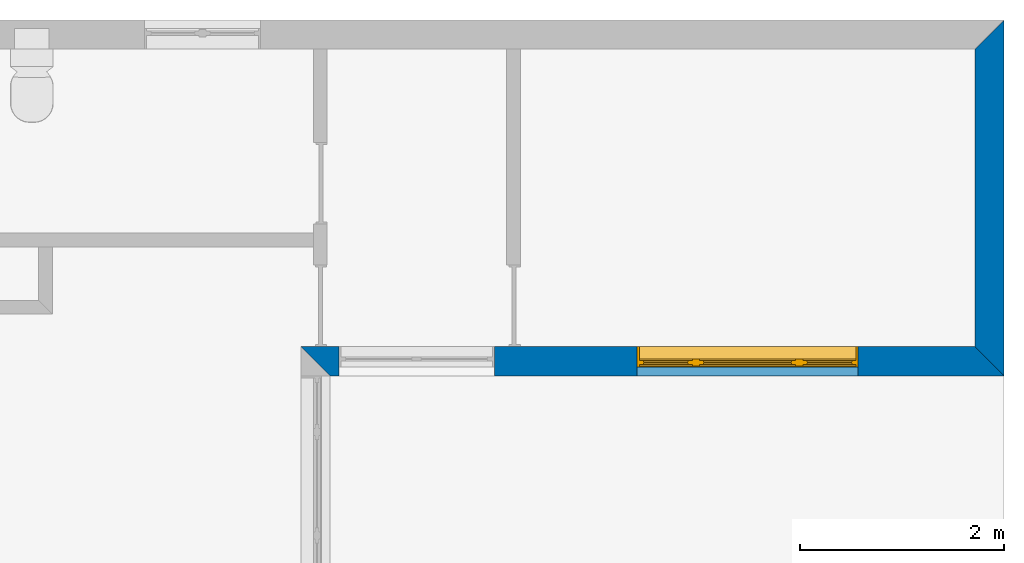
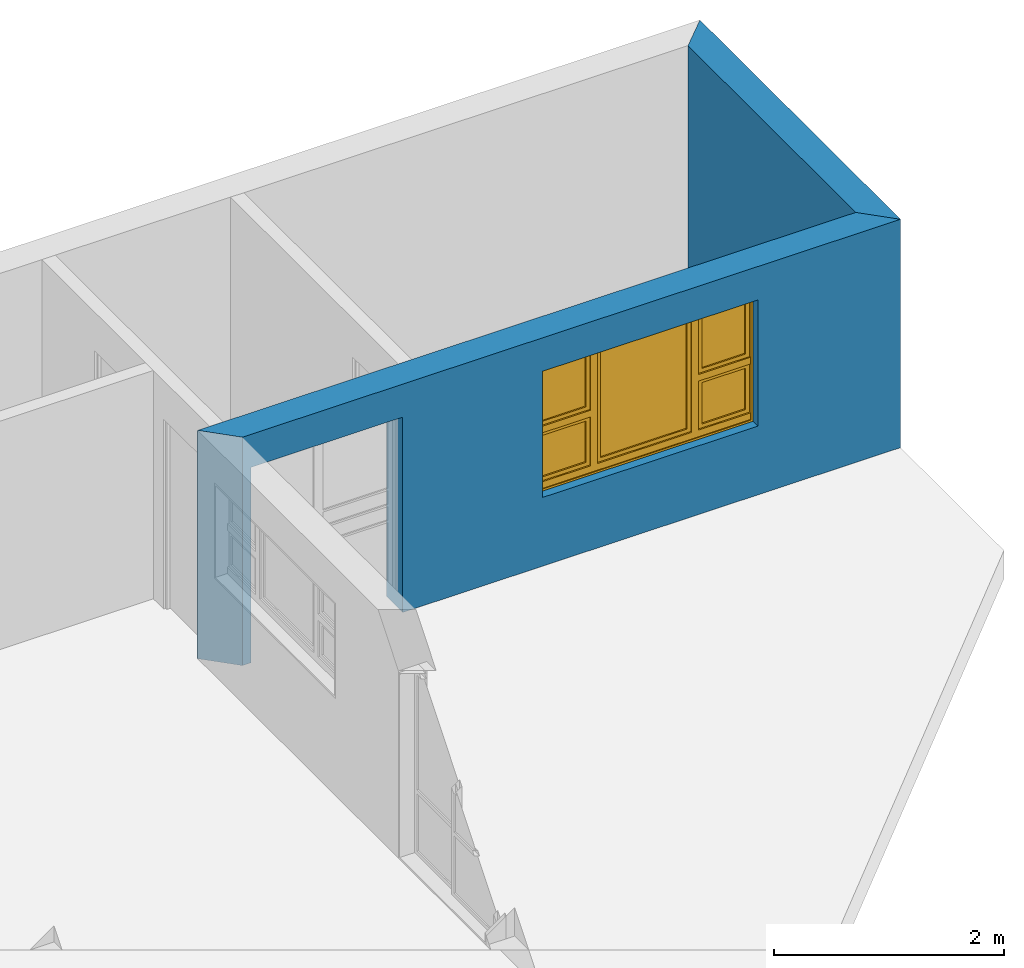
# One storey, part 7 of 15: 2 walls, 1 window, 2 openings.
"""IFC4 building model written with IfcOpenShell, lengths in millimetres."""

from ifc_helpers import new_model, entity, si_unit, converted_unit, frame, origin_with_axes, origin_2d_with_axis, place, context, subcontext, project, spatial, line, indexed_curve, outline, extrude, clip, halfspace, polygons, source, transform, mapped, material, layer, layer_set, layer_usage, type_object, type_shapes, element, fill, save


model = new_model("IFC4")

# Units and contexts
model_context = context("Model", 3, precision=1e-05, world=origin_with_axes())
plan_context = context("Plan", 2, precision=1e-05, world=origin_2d_with_axis())
body_context = subcontext(model_context, "Body", "Model", "MODEL_VIEW")
ifc_project = project(units=[si_unit("VOLUMEUNIT", "CUBIC_METRE"), si_unit("LENGTHUNIT", "METRE", prefix="MILLI"), converted_unit("PLANEANGLEUNIT", "degree", entity("IfcReal", 0.0174532925199433), si_unit("PLANEANGLEUNIT", "RADIAN"), dimensions=[0, 0, 0, 0, 0, 0, 0]), si_unit("AREAUNIT", "SQUARE_METRE")], contexts=[model_context, plan_context])

# Site, building, storey
site_placement = place(None, origin_with_axes())
site = spatial("IfcSite", under=ifc_project, at=site_placement)
building_placement = place(site_placement, origin_with_axes())
building = spatial("IfcBuilding", under=site, at=building_placement, Name="Building")
storey_placement = place(building_placement, origin_with_axes())
storey = spatial("IfcBuildingStorey", under=building, at=storey_placement, Name="EXISTING")

# Wall, openings, window
ifc_material = material()
ifc_layer = layer(ifc_material, 285.0, Name="brick")
ifc_layer_set = layer_set([ifc_layer])
ifc_layer_usage_1 = layer_usage(ifc_layer_set, "AXIS2", "POSITIVE", 0.0)
wall_type = type_object("IfcWallType", Name="285mm Wall", PredefinedType="STANDARD", material=ifc_layer_set)
wall_1_placement = place(storey_placement, frame((13209.1217041016, 2256.66809082031, 0.0), z_axis=(0.0, 0.0, 1.0), x_axis=(0.999999999999993, 1.19209282445353e-07, 0.0)))
wall_1 = element("IfcWall", 1, at=wall_1_placement, inside=storey, type_object=wall_type, material=ifc_layer_usage_1, Name="Wall", context=body_context, shape_type="Clipping", body=[
    clip(clip(extrude(outline(indexed_curve([(0.0, 0.0), (0.0, 285.0), (6894.99959678732, 285.0), (6894.99959678732, 0.0), (0.0, 0.0)], self_intersect=False)), origin_with_axes(), (0.0, 0.0, 1.0), 2425.00019073486), halfspace(frame((284.999847412109, 0.0, 0.0), z_axis=(-0.70710676908493, -0.70710676908493, 0.0), x_axis=(-0.707106781186547, 0.707106781186547, 0.0)), False)), halfspace(frame((6894.99950408936, 0.0, 0.0), z_axis=(0.70710676908493, 0.70710676908493, 0.0), x_axis=(0.707106781186547, -0.707106781186547, 0.0)), False)),
])
shared_shape_1 = source(origin_with_axes(), body_context, "Body", "SweptSolid", [
    extrude(outline(indexed_curve([(0.0, 0.0), (2165.00048828125, 0.0), (2165.00048828125, 1340.00048828125), (0.0, 1340.00048828125)], segments=[line(1, 2, 3, 4, 1)])), frame((-5.96046390910487e-07, -600.0, 0.0), z_axis=(0.0, -1.0, 0.0), x_axis=(1.0, 0.0, 0.0)), (0.0, 0.0, -1.0), 1200.0),
])
opening_1_placement = place(wall_1_placement, frame((5461.99893951417, 136.110782623295, 730.000019073486), z_axis=(0.0, 0.0, 1.0), x_axis=(-0.999999999999989, 1.50995802528085e-07, 0.0)))
opening_1 = element("IfcOpeningElement", 2, at=opening_1_placement, cuts=wall_1, Name="Opening", PredefinedType="OPENING", context=body_context, shape_type="MappedRepresentation", body=[
    mapped(shared_shape_1, transform((0.0, 0.0, 0.0), x_axis=(1.0, 0.0, 0.0), y_axis=(0.0, 1.0, 0.0), z_axis=(0.0, 0.0, 1.0), scale=1.0)),
])
shared_shape_2 = source(origin_with_axes(), body_context, "Body", "SweptSolid", [
    extrude(outline(indexed_curve([(0.0, 0.0), (1525.00244140625, 0.0), (1525.00244140625, 2075.0029296875), (0.0, 2075.0029296875)], segments=[line(1, 2, 3, 4, 1)])), frame((1.19209282445354e-07, -600.0, 0.0), z_axis=(0.0, -1.0, 0.0), x_axis=(1.0, 0.0, 0.0)), (0.0, 0.0, -1.0), 1200.0),
])
opening_2_placement = place(wall_1_placement, frame((1895.00141143799, -33.8461399078334, 0.0), z_axis=(0.0, 0.0, 1.0), x_axis=(-0.999999999999989, 1.50995802528085e-07, 0.0)))
element("IfcOpeningElement", 3, at=opening_2_placement, cuts=wall_1, PredefinedType="OPENING", context=body_context, shape_type="MappedRepresentation", body=[
    mapped(shared_shape_2, transform((0.0, 0.0, 0.0), x_axis=(1.0, 0.0, 0.0), y_axis=(0.0, 1.0, 0.0), z_axis=(0.0, 0.0, 1.0), scale=1.0)),
])
window_type = type_object("IfcWindowType", Name="Ex.2165x1340", PartitioningType="NOTDEFINED", PredefinedType="WINDOW")
shared_shape_3 = source(origin_with_axes(), body_context, "Body", "Tessellation", [
    polygons([(2165.00024414062, -148.888916015625, 0.0), (2165.00024414062, -148.888916015625, 19.999979019165), (0.000119209282274824, -148.888977050781, 0.0), (0.000119209282274824, -148.888977050781, 19.999979019165), (2165.00024414062, 51.1110572814941, 0.0), (2165.00024414062, 51.1110572814941, 19.999979019165), (0.000119209282274824, 51.1110000610352, 0.0), (0.000119209282274824, 51.1110000610352, 19.999979019165), (2165.00024414062, -148.888916015625, 1320.00048828125), (2165.00024414062, -148.888916015625, 1340.00048828125), (0.000119209282274824, -148.888977050781, 1320.00048828125), (0.000119209282274824, -148.888977050781, 1340.00048828125), (2165.00024414062, 51.1110572814941, 1320.00048828125), (2165.00024414062, 51.1110572814941, 1340.00048828125), (0.000119209282274824, 51.1110000610352, 1320.00048828125), (0.000119209282274824, 51.1110000610352, 1340.00048828125), (0.000119209282274824, -148.888916015625, 19.9999198913574), (19.9998607635498, -148.888916015625, 19.9999198913574), (-0.000357627839548513, -148.888977050781, 1340.00036621094), (19.9996223449707, -148.888977050781, 1340.00036621094), (0.000119209282274824, 51.1110572814941, 19.9999198913574), (19.9998607635498, 51.1110572814941, 19.9999198913574), (-0.000596046389546245, 51.1110000610352, 1340.00036621094), (19.9996223449707, 51.1110000610352, 1340.00036621094), (2145.00024414062, -148.888916015625, 19.9999198913574), (2165.00024414062, -148.888916015625, 19.9999198913574), (2144.99975585938, -148.888977050781, 1340.00036621094), (2164.99975585938, -148.888977050781, 1340.00036621094), (2145.00024414062, 51.1110572814941, 19.9999198913574), (2165.00024414062, 51.1110572814941, 19.9999198913574), (2144.99975585938, 51.1110000610352, 1340.00036621094), (2164.99975585938, 51.1110000610352, 1340.00036621094), (1554.99975585938, -28.8889198303223, 19.9999198913574), (1624.99987792969, -28.8889198303223, 19.9999198913574), (1554.99951171875, -28.8889198303223, 1340.00048828125), (1624.99938964844, -28.8889198303223, 1340.00048828125), (1554.99975585938, 41.1110687255859, 19.9999198913574), (1624.99987792969, 41.1110687255859, 19.9999198913574), (1554.99951171875, 41.1110076904297, 1340.00048828125), (1624.99938964844, 41.1110687255859, 1340.00048828125), (539.999938964844, -28.8889198303223, 19.9999198913574), (609.999633789062, -28.8889198303223, 19.9999198913574), (539.999450683594, -28.8889198303223, 1340.00048828125), (609.999633789062, -28.8889198303223, 1340.00048828125), (539.999938964844, 41.1110687255859, 19.9999198913574), (609.999633789062, 41.1110687255859, 19.9999198913574), (539.999450683594, 41.1110076904297, 1340.00048828125), (609.999633789062, 41.1110687255859, 1340.00048828125), (19.9998607635498, -28.8889808654785, 679.999328613281), (19.9998607635498, -28.8889808654785, 609.999877929688), (539.999938964844, -28.8889198303223, 680.0), (539.999938964844, -28.8888607025146, 610.000671386719), (19.9998607635498, 41.1109504699707, 679.999328613281), (19.9998607635498, 41.1110076904297, 609.999877929688), (539.999938964844, 41.1110687255859, 680.0), (539.999938964844, 41.1110687255859, 610.000671386719), (1624.99987792969, -28.8889808654785, 679.999328613281), (1624.99987792969, -28.8889808654785, 609.999877929688), (2144.99975585938, -28.8889198303223, 680.0), (2144.99975585938, -28.8888607025146, 610.000671386719), (1624.99987792969, 41.1109504699707, 679.999328613281), (1624.99987792969, 41.1110076904297, 609.999877929688), (2144.99975585938, 41.1110687255859, 680.0), (2144.99975585938, 41.1110687255859, 610.000671386719), (1624.99987792969, -13.8889951705933, 1319.99987792969), (1624.99987792969, -13.8889951705933, 1280.00024414062), (2144.99975585938, -13.8889360427856, 1320.00048828125), (2144.99975585938, -13.8889360427856, 1280.00073242188), (1624.99987792969, 26.1109638214111, 1319.99987792969), (1624.99987792969, 26.1109638214111, 1280.00024414062), (2144.99975585938, 26.111083984375, 1320.00048828125), (2144.99975585938, 26.111083984375, 1280.00073242188), (1624.99987792969, -13.8889951705933, 719.9990234375), (1624.99987792969, -13.8889951705933, 679.999328613281), (2144.99975585938, -13.8889360427856, 719.99951171875), (2144.99975585938, -13.8889360427856, 679.999816894531), (1624.99987792969, 26.1109638214111, 719.9990234375), (1624.99987792969, 26.1109638214111, 679.999328613281), (2144.99975585938, 26.111083984375, 719.99951171875), (2144.99975585938, 26.111083984375, 679.999816894531), (1664.99987792969, -13.8889360427856, 1280.00024414062), (1624.99987792969, -13.8889360427856, 1280.00024414062), (1664.99987792969, -13.8889360427856, 719.998779296875), (1624.99987792969, -13.8889360427856, 719.998779296875), (1664.99987792969, 26.111083984375, 1280.00024414062), (1624.99987792969, 26.111083984375, 1280.00024414062), (1664.99987792969, 26.111083984375, 719.998779296875), (1624.99987792969, 26.111083984375, 719.998779296875), (2144.99926757812, -13.8889360427856, 1280.00024414062), (2105.0, -13.8889360427856, 1280.00024414062), (2144.99877929688, -13.8889360427856, 719.998779296875), (2104.99951171875, -13.8889360427856, 719.998779296875), (2144.99926757812, 26.111083984375, 1280.00024414062), (2105.0, 26.111083984375, 1280.00024414062), (2144.99877929688, 26.111083984375, 719.998779296875), (2104.99951171875, 26.111083984375, 719.998779296875), (19.9998607635498, -13.8889951705933, 1319.99987792969), (19.9998607635498, -13.8889951705933, 1280.00024414062), (539.999938964844, -13.8889360427856, 1320.00048828125), (539.999938964844, -13.8889360427856, 1280.00073242188), (19.9998607635498, 26.1109638214111, 1319.99987792969), (19.9998607635498, 26.1109638214111, 1280.00024414062), (539.999938964844, 26.111083984375, 1320.00048828125), (539.999938964844, 26.111083984375, 1280.00073242188), (19.9998607635498, -13.8889951705933, 719.9990234375), (19.9998607635498, -13.8889951705933, 679.999328613281), (539.999938964844, -13.8889360427856, 719.99951171875), (539.999938964844, -13.8889360427856, 679.999816894531), (19.9998607635498, 26.1109638214111, 719.9990234375), (19.9998607635498, 26.1109638214111, 679.999328613281), (539.999938964844, 26.111083984375, 719.99951171875), (539.999938964844, 26.111083984375, 679.999816894531), (60.0002975463867, -13.8889360427856, 1280.00024414062), (20.000337600708, -13.8889360427856, 1280.00024414062), (59.9998207092285, -13.8889360427856, 719.998779296875), (20.000337600708, -13.8889360427856, 719.998779296875), (60.0002975463867, 26.111083984375, 1280.00024414062), (20.000337600708, 26.111083984375, 1280.00024414062), (59.9998207092285, 26.111083984375, 719.998779296875), (20.000337600708, 26.111083984375, 719.998779296875), (539.999450683594, -13.8889360427856, 1280.00024414062), (499.999603271484, -13.8889360427856, 1280.00024414062), (539.999450683594, -13.8889360427856, 719.998779296875), (499.999603271484, -13.8889360427856, 719.998779296875), (539.999450683594, 26.111083984375, 1280.00024414062), (499.999603271484, 26.111083984375, 1280.00024414062), (539.999450683594, 26.111083984375, 719.998779296875), (499.999603271484, 26.111083984375, 719.998779296875), (19.9998607635498, -28.8889808654785, 89.9991912841797), (19.9998607635498, -28.8889808654785, 19.9998016357422), (539.999938964844, -28.8889198303223, 89.9999694824219), (539.999938964844, -28.8888607025146, 20.0005760192871), (19.9998607635498, 41.1109504699707, 89.9991912841797), (19.9998607635498, 41.1110076904297, 19.9998016357422), (539.999938964844, 41.1110687255859, 90.0000305175781), (539.999938964844, 41.1110687255859, 20.0005760192871), (1624.99987792969, -28.8889808654785, 89.9991912841797), (1624.99987792969, -28.8889808654785, 19.9998016357422), (2144.99975585938, -28.8889198303223, 89.9999694824219), (2144.99975585938, -28.8888607025146, 20.0005760192871), (1624.99987792969, 41.1109504699707, 89.9991912841797), (1624.99987792969, 41.1110076904297, 19.9998016357422), (2144.99975585938, 41.1110687255859, 90.0000305175781), (2144.99975585938, 41.1110687255859, 20.0005760192871), (610.000122070312, -28.8889808654785, 89.9991912841797), (610.000122070312, -28.8889808654785, 19.9998016357422), (1554.99975585938, -28.8889198303223, 89.9999694824219), (1554.99975585938, -28.8889198303223, 20.0005760192871), (610.000122070312, 41.1109504699707, 89.9991912841797), (610.000122070312, 41.1110076904297, 19.9998016357422), (1554.99975585938, 41.1110687255859, 90.0000305175781), (1554.99975585938, 41.1110687255859, 20.0005760192871), (1624.99987792969, -13.8889951705933, 610.0), (1624.99987792969, -13.8889951705933, 570.000366210938), (2144.99975585938, -13.8889360427856, 610.000549316406), (2144.99975585938, -13.8889360427856, 570.000854492188), (1624.99987792969, 26.1109638214111, 610.0), (1624.99987792969, 26.1109638214111, 570.000366210938), (2144.99975585938, 26.111083984375, 610.000549316406), (2144.99975585938, 26.111083984375, 570.000854492188), (1624.99987792969, -13.8889951705933, 129.999694824219), (1624.99987792969, -13.8889951705933, 90.0000305175781), (2144.99975585938, -13.8889360427856, 130.000228881836), (2144.99975585938, -13.8889360427856, 90.0005645751953), (1624.99987792969, 26.1109638214111, 129.999755859375), (1624.99987792969, 26.1109638214111, 90.0000305175781), (2144.99975585938, 26.111083984375, 130.000228881836), (2144.99975585938, 26.111083984375, 90.0005645751953), (1664.99987792969, -13.8889360427856, 570.000366210938), (1624.99987792969, -13.8889360427856, 570.000366210938), (1664.99987792969, -13.8889360427856, 129.999099731445), (1624.99987792969, -13.8889360427856, 129.999145507812), (1664.99987792969, 26.111083984375, 570.000366210938), (1624.99987792969, 26.111083984375, 570.000366210938), (1664.99987792969, 26.111083984375, 129.999099731445), (1624.99987792969, 26.111083984375, 129.999145507812), (2144.99926757812, -13.8889360427856, 570.000366210938), (2105.0, -13.8889360427856, 570.000366210938), (2144.99877929688, -13.8889360427856, 129.999099731445), (2104.99951171875, -13.8889360427856, 129.999145507812), (2144.99926757812, 26.111083984375, 570.000366210938), (2105.0, 26.111083984375, 570.000366210938), (2144.99877929688, 26.111083984375, 129.999099731445), (2104.99951171875, 26.111083984375, 129.999145507812), (19.9998607635498, -13.8889951705933, 610.0), (19.9998607635498, -13.8889951705933, 570.000366210938), (539.999938964844, -13.8889360427856, 610.000549316406), (539.999938964844, -13.8889360427856, 570.000854492188), (19.9998607635498, 26.1109638214111, 610.0), (19.9998607635498, 26.1109638214111, 570.000366210938), (539.999938964844, 26.111083984375, 610.000549316406), (539.999938964844, 26.111083984375, 570.000854492188), (19.9998607635498, -13.8889951705933, 129.998611450195), (19.9998607635498, -13.8889951705933, 89.9989547729492), (539.999938964844, -13.8889360427856, 129.999145507812), (539.999938964844, -13.8889360427856, 89.9994888305664), (19.9998607635498, 26.1109638214111, 129.998672485352), (19.9998607635498, 26.1109638214111, 89.9989547729492), (539.999938964844, 26.111083984375, 129.999145507812), (539.999938964844, 26.111083984375, 89.9994888305664), (60.0002975463867, -13.8889360427856, 570.000366210938), (20.000337600708, -13.8889360427856, 570.000366210938), (59.9998207092285, -13.8889360427856, 129.999099731445), (20.000337600708, -13.8889360427856, 129.999145507812), (60.0002975463867, 26.111083984375, 570.000366210938), (20.000337600708, 26.111083984375, 570.000366210938), (59.9998207092285, 26.111083984375, 129.999099731445), (20.000337600708, 26.111083984375, 129.999145507812), (539.999450683594, -13.8889360427856, 570.000366210938), (499.999603271484, -13.8889360427856, 570.000366210938), (539.999450683594, -13.8889360427856, 129.999099731445), (499.999603271484, -13.8889360427856, 129.999145507812), (539.999450683594, 26.111083984375, 570.000366210938), (499.999603271484, 26.111083984375, 570.000366210938), (539.999450683594, 26.111083984375, 129.999099731445), (499.999603271484, 26.111083984375, 129.999145507812), (610.000122070312, -13.8889951705933, 1319.99987792969), (610.000122070312, -13.8889951705933, 1280.00024414062), (1554.99951171875, -13.8889360427856, 1320.00048828125), (1554.99951171875, -13.8889360427856, 1280.00073242188), (610.000122070312, 26.1109638214111, 1319.99987792969), (610.000122070312, 26.1109638214111, 1280.00024414062), (1554.99951171875, 26.111083984375, 1320.00048828125), (1554.99951171875, 26.111083984375, 1280.00073242188), (610.000122070312, -13.8889951705933, 129.998916625977), (610.000122070312, -13.8889951705933, 89.9992523193359), (1554.99951171875, -13.8889360427856, 129.999450683594), (1554.99951171875, -13.8889360427856, 89.9997863769531), (610.000122070312, 26.1109638214111, 129.998916625977), (610.000122070312, 26.1109638214111, 89.9992523193359), (1554.99951171875, 26.111083984375, 129.99951171875), (1554.99951171875, 26.111083984375, 89.9997863769531), (650.000549316406, -13.8889360427856, 1280.00024414062), (610.000549316406, -13.8889360427856, 1280.00024414062), (650.000061035156, -13.8889360427856, 129.999450683594), (610.000549316406, -13.8889360427856, 129.999450683594), (650.000549316406, 26.111083984375, 1280.00024414062), (610.000549316406, 26.111083984375, 1280.00024414062), (650.000061035156, 26.111083984375, 129.999450683594), (610.000549316406, 26.111083984375, 129.999450683594), (1554.99975585938, -13.8889360427856, 1280.00024414062), (1514.99975585938, -13.8889360427856, 1280.00024414062), (1554.99926757812, -13.8889360427856, 129.999389648438), (1514.99975585938, -13.8889360427856, 129.999389648438), (1554.99975585938, 26.111083984375, 1280.00024414062), (1514.99975585938, 26.111083984375, 1280.00024414062), (1554.99951171875, 26.111083984375, 129.999389648438), (1514.99975585938, 26.111083984375, 129.999389648438), (1515.00024414062, 1.11104917526245, 1280.00024414062), (650.001037597656, 1.11104917526245, 1280.00024414062), (1514.99975585938, 1.11104917526245, 129.999389648438), (650.001037597656, 1.11104917526245, 129.999450683594), (1515.00024414062, 11.1110391616821, 1280.00024414062), (650.001037597656, 11.1110982894897, 1280.00024414062), (1514.99975585938, 11.1110391616821, 129.999389648438), (650.001037597656, 11.1110982894897, 129.999450683594), (2104.99853515625, 1.11104917526245, 1280.00024414062), (1664.99963378906, 1.11104917526245, 1280.00036621094), (2104.998046875, 1.11104917526245, 719.999267578125), (1664.99938964844, 1.11104917526245, 719.999267578125), (2104.99853515625, 11.1110391616821, 1280.00024414062), (1664.99963378906, 11.1110982894897, 1280.00036621094), (2104.998046875, 11.1110391616821, 719.999267578125), (1664.99938964844, 11.1110982894897, 719.999267578125), (2104.99853515625, 1.11104917526245, 570.000244140625), (1664.99963378906, 1.11104917526245, 570.000244140625), (2104.998046875, 1.11104917526245, 130.000579833984), (1664.99938964844, 1.11104917526245, 130.000579833984), (2104.99853515625, 11.1110391616821, 570.000244140625), (1664.99963378906, 11.1110982894897, 570.000244140625), (2104.998046875, 11.1110391616821, 130.000579833984), (1664.99938964844, 11.1110982894897, 130.000579833984), (499.998657226562, 1.11104917526245, 1280.00024414062), (60.000057220459, 1.11104917526245, 1280.00036621094), (499.998657226562, 1.11104917526245, 719.999267578125), (59.9998207092285, 1.11104917526245, 719.999267578125), (499.998657226562, 11.1110391616821, 1280.00024414062), (60.000057220459, 11.1110982894897, 1280.00036621094), (499.998657226562, 11.1110391616821, 719.999267578125), (59.9998207092285, 11.1110982894897, 719.999267578125), (499.998657226562, 1.11104917526245, 570.000244140625), (60.000057220459, 1.11104917526245, 570.000244140625), (499.998413085938, 1.11104917526245, 130.000579833984), (59.9998207092285, 1.11104917526245, 130.000579833984), (499.998657226562, 11.1110391616821, 570.000244140625), (60.000057220459, 11.1110982894897, 570.000244140625), (499.998413085938, 11.1110391616821, 130.000579833984), (59.9998207092285, 11.1110982894897, 130.000579833984)], [[[1, 2, 4, 3]], [[3, 4, 8, 7]], [[7, 8, 6, 5]], [[5, 6, 2, 1]], [[3, 7, 5, 1]], [[8, 4, 2, 6]], [[9, 10, 12, 11]], [[11, 12, 16, 15]], [[15, 16, 14, 13]], [[13, 14, 10, 9]], [[11, 15, 13, 9]], [[16, 12, 10, 14]], [[17, 18, 20, 19]], [[19, 20, 24, 23]], [[23, 24, 22, 21]], [[21, 22, 18, 17]], [[19, 23, 21, 17]], [[24, 20, 18, 22]], [[25, 26, 28, 27]], [[27, 28, 32, 31]], [[31, 32, 30, 29]], [[29, 30, 26, 25]], [[27, 31, 29, 25]], [[32, 28, 26, 30]], [[33, 34, 36, 35]], [[35, 36, 40, 39]], [[39, 40, 38, 37]], [[37, 38, 34, 33]], [[35, 39, 37, 33]], [[40, 36, 34, 38]], [[41, 42, 44, 43]], [[43, 44, 48, 47]], [[47, 48, 46, 45]], [[45, 46, 42, 41]], [[43, 47, 45, 41]], [[48, 44, 42, 46]], [[49, 50, 52, 51]], [[51, 52, 56, 55]], [[55, 56, 54, 53]], [[53, 54, 50, 49]], [[51, 55, 53, 49]], [[56, 52, 50, 54]], [[57, 58, 60, 59]], [[59, 60, 64, 63]], [[63, 64, 62, 61]], [[61, 62, 58, 57]], [[59, 63, 61, 57]], [[64, 60, 58, 62]], [[65, 66, 68, 67]], [[67, 68, 72, 71]], [[71, 72, 70, 69]], [[69, 70, 66, 65]], [[67, 71, 69, 65]], [[72, 68, 66, 70]], [[73, 74, 76, 75]], [[75, 76, 80, 79]], [[79, 80, 78, 77]], [[77, 78, 74, 73]], [[75, 79, 77, 73]], [[80, 76, 74, 78]], [[81, 82, 84, 83]], [[83, 84, 88, 87]], [[87, 88, 86, 85]], [[85, 86, 82, 81]], [[83, 87, 85, 81]], [[88, 84, 82, 86]], [[89, 90, 92, 91]], [[91, 92, 96, 95]], [[95, 96, 94, 93]], [[93, 94, 90, 89]], [[91, 95, 93, 89]], [[96, 92, 90, 94]], [[97, 98, 100, 99]], [[99, 100, 104, 103]], [[103, 104, 102, 101]], [[101, 102, 98, 97]], [[99, 103, 101, 97]], [[104, 100, 98, 102]], [[105, 106, 108, 107]], [[107, 108, 112, 111]], [[111, 112, 110, 109]], [[109, 110, 106, 105]], [[107, 111, 109, 105]], [[112, 108, 106, 110]], [[113, 114, 116, 115]], [[115, 116, 120, 119]], [[119, 120, 118, 117]], [[117, 118, 114, 113]], [[115, 119, 117, 113]], [[120, 116, 114, 118]], [[121, 122, 124, 123]], [[123, 124, 128, 127]], [[127, 128, 126, 125]], [[125, 126, 122, 121]], [[123, 127, 125, 121]], [[128, 124, 122, 126]], [[129, 130, 132, 131]], [[131, 132, 136, 135]], [[135, 136, 134, 133]], [[133, 134, 130, 129]], [[131, 135, 133, 129]], [[136, 132, 130, 134]], [[137, 138, 140, 139]], [[139, 140, 144, 143]], [[143, 144, 142, 141]], [[141, 142, 138, 137]], [[139, 143, 141, 137]], [[144, 140, 138, 142]], [[145, 146, 148, 147]], [[147, 148, 152, 151]], [[151, 152, 150, 149]], [[149, 150, 146, 145]], [[147, 151, 149, 145]], [[152, 148, 146, 150]], [[153, 154, 156, 155]], [[155, 156, 160, 159]], [[159, 160, 158, 157]], [[157, 158, 154, 153]], [[155, 159, 157, 153]], [[160, 156, 154, 158]], [[161, 162, 164, 163]], [[163, 164, 168, 167]], [[167, 168, 166, 165]], [[165, 166, 162, 161]], [[163, 167, 165, 161]], [[168, 164, 162, 166]], [[169, 170, 172, 171]], [[171, 172, 176, 175]], [[175, 176, 174, 173]], [[173, 174, 170, 169]], [[171, 175, 173, 169]], [[176, 172, 170, 174]], [[177, 178, 180, 179]], [[179, 180, 184, 183]], [[183, 184, 182, 181]], [[181, 182, 178, 177]], [[179, 183, 181, 177]], [[184, 180, 178, 182]], [[185, 186, 188, 187]], [[187, 188, 192, 191]], [[191, 192, 190, 189]], [[189, 190, 186, 185]], [[187, 191, 189, 185]], [[192, 188, 186, 190]], [[193, 194, 196, 195]], [[195, 196, 200, 199]], [[199, 200, 198, 197]], [[197, 198, 194, 193]], [[195, 199, 197, 193]], [[200, 196, 194, 198]], [[201, 202, 204, 203]], [[203, 204, 208, 207]], [[207, 208, 206, 205]], [[205, 206, 202, 201]], [[203, 207, 205, 201]], [[208, 204, 202, 206]], [[209, 210, 212, 211]], [[211, 212, 216, 215]], [[215, 216, 214, 213]], [[213, 214, 210, 209]], [[211, 215, 213, 209]], [[216, 212, 210, 214]], [[217, 218, 220, 219]], [[219, 220, 224, 223]], [[223, 224, 222, 221]], [[221, 222, 218, 217]], [[219, 223, 221, 217]], [[224, 220, 218, 222]], [[225, 226, 228, 227]], [[227, 228, 232, 231]], [[231, 232, 230, 229]], [[229, 230, 226, 225]], [[227, 231, 229, 225]], [[232, 228, 226, 230]], [[233, 234, 236, 235]], [[235, 236, 240, 239]], [[239, 240, 238, 237]], [[237, 238, 234, 233]], [[235, 239, 237, 233]], [[240, 236, 234, 238]], [[241, 242, 244, 243]], [[243, 244, 248, 247]], [[247, 248, 246, 245]], [[245, 246, 242, 241]], [[243, 247, 245, 241]], [[248, 244, 242, 246]], [[249, 250, 252, 251]], [[251, 252, 256, 255]], [[255, 256, 254, 253]], [[253, 254, 250, 249]], [[251, 255, 253, 249]], [[256, 252, 250, 254]], [[257, 258, 260, 259]], [[259, 260, 264, 263]], [[263, 264, 262, 261]], [[261, 262, 258, 257]], [[259, 263, 261, 257]], [[264, 260, 258, 262]], [[265, 266, 268, 267]], [[267, 268, 272, 271]], [[271, 272, 270, 269]], [[269, 270, 266, 265]], [[267, 271, 269, 265]], [[272, 268, 266, 270]], [[273, 274, 276, 275]], [[275, 276, 280, 279]], [[279, 280, 278, 277]], [[277, 278, 274, 273]], [[275, 279, 277, 273]], [[280, 276, 274, 278]], [[281, 282, 284, 283]], [[283, 284, 288, 287]], [[287, 288, 286, 285]], [[285, 286, 282, 281]], [[283, 287, 285, 281]], [[288, 284, 282, 286]]], closed=True),
])
type_shapes(window_type, [shared_shape_3])
window_placement = place(opening_1_placement, frame((0.00093744861118239, 0.00017428384868623, 3.33066907387547e-13), z_axis=(0.0, 0.0, 1.0), x_axis=(0.999999999999993, -1.19209282445353e-07, 0.0)))
window = element("IfcWindow", 4, at=window_placement, inside=storey, type_object=window_type, Name="Window", context=body_context, shape_type="MappedRepresentation", body=[
    mapped(shared_shape_3, transform((0.0, 0.0, 0.0), x_axis=(1.0, 0.0, 0.0), y_axis=(0.0, 1.0, 0.0), z_axis=(0.0, 0.0, 1.0), scale=1.0)),
])
fill(opening_1, window)

# Wall
ifc_layer_usage_2 = layer_usage(ifc_layer_set, "AXIS2", "POSITIVE", 0.0)
wall_2_placement = place(storey_placement, frame((20104.1221618652, 2256.667137146, 0.0), z_axis=(0.0, 0.0, 1.0), x_axis=(3.13916473260163e-07, 0.999999999999951, 0.0)))
element("IfcWall", 5, at=wall_2_placement, inside=storey, type_object=wall_type, material=ifc_layer_usage_2, Name="Wall", context=body_context, shape_type="Clipping", body=[
    clip(clip(extrude(outline(indexed_curve([(0.0, 0.0), (0.0, 285.0), (3489.99951665976, 285.0), (3489.99951665976, 0.0), (0.0, 0.0)], self_intersect=False)), origin_with_axes(), (0.0, 0.0, 1.0), 2425.00019073486), halfspace(frame((0.000190887021744857, -0.000676795934850816, 0.0), z_axis=(-0.70710700750351, 0.707106530666351, 0.0), x_axis=(0.707106542767924, 0.70710701960509, 0.0)), False)), halfspace(frame((3490.00000953674, -0.00148857611748099, 0.0), z_axis=(0.707106530666351, 0.70710700750351, 0.0), x_axis=(0.70710701960509, -0.707106542767924, 0.0)), False)),
])

save(model, "model.ifc")
